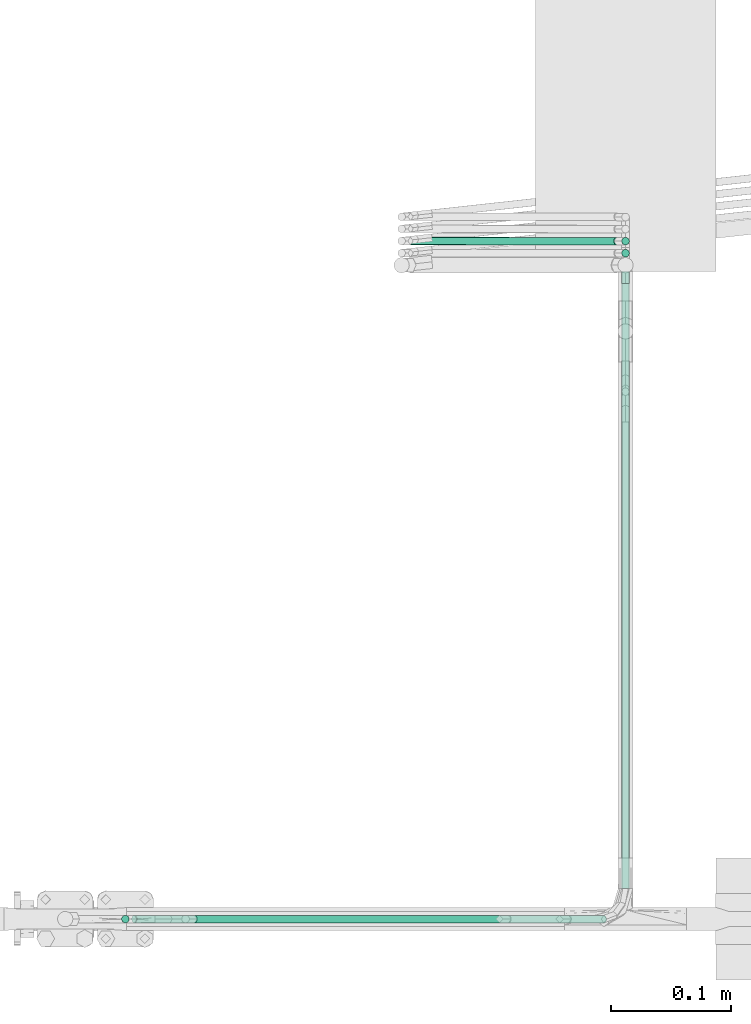
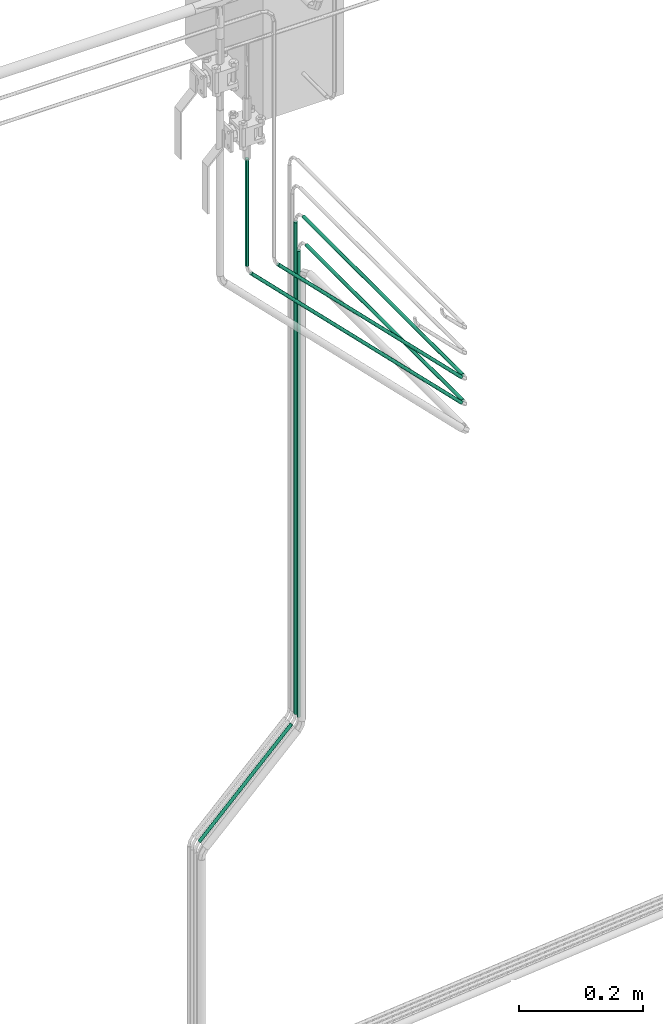
# One storey, part 11 of 45: 8 flow segments.
"""IFC2X3 building model written with IfcOpenShell, lengths in millimetres."""

from ifc_helpers import new_model, entity, si_unit, converted_unit, derived_unit, direction, frame, origin, origin_2d_with_axis, place, context, subcontext, project, spatial, circle, extrude, type_object, element, save


model = new_model("IFC2X3")

# Units and contexts
model_context = context("Model", 3, precision=0.01, world=origin(), true_north=direction((6.12303176911189e-17, 1.0)))
body_context = subcontext(model_context, "Body", "Model", "MODEL_VIEW")
ifc_project = project(units=[si_unit("LENGTHUNIT", "METRE", prefix="MILLI"), si_unit("AREAUNIT", "SQUARE_METRE"), si_unit("VOLUMEUNIT", "CUBIC_METRE"), converted_unit("PLANEANGLEUNIT", "DEGREE", entity("IfcRatioMeasure", 0.0174532925199433), si_unit("PLANEANGLEUNIT", "RADIAN"), dimensions=[0, 0, 0, 0, 0, 0, 0]), si_unit("MASSUNIT", "GRAM", prefix="KILO"), derived_unit("MASSDENSITYUNIT", [(si_unit("MASSUNIT", "GRAM", prefix="KILO"), 1), (si_unit("LENGTHUNIT", "METRE"), -3)]), derived_unit("MOMENTOFINERTIAUNIT", [(si_unit("LENGTHUNIT", "METRE"), 4)]), si_unit("TIMEUNIT", "SECOND"), si_unit("FREQUENCYUNIT", "HERTZ"), si_unit("THERMODYNAMICTEMPERATUREUNIT", "DEGREE_CELSIUS"), derived_unit("THERMALTRANSMITTANCEUNIT", [(si_unit("MASSUNIT", "GRAM", prefix="KILO"), 1), (si_unit("THERMODYNAMICTEMPERATUREUNIT", "KELVIN"), -1), (si_unit("TIMEUNIT", "SECOND"), -3)]), derived_unit("VOLUMETRICFLOWRATEUNIT", [(si_unit("LENGTHUNIT", "METRE"), 3), (si_unit("TIMEUNIT", "SECOND"), -1)]), derived_unit("MASSFLOWRATEUNIT", [(si_unit("MASSUNIT", "GRAM", prefix="KILO"), 1), (si_unit("TIMEUNIT", "SECOND"), -1)]), derived_unit("ROTATIONALFREQUENCYUNIT", [(si_unit("TIMEUNIT", "SECOND"), -1)]), si_unit("ELECTRICCURRENTUNIT", "AMPERE"), si_unit("ELECTRICVOLTAGEUNIT", "VOLT"), si_unit("POWERUNIT", "WATT"), si_unit("FORCEUNIT", "NEWTON", prefix="KILO"), si_unit("ILLUMINANCEUNIT", "LUX"), si_unit("LUMINOUSFLUXUNIT", "LUMEN"), si_unit("LUMINOUSINTENSITYUNIT", "CANDELA"), derived_unit("USERDEFINED", [(si_unit("MASSUNIT", "GRAM", prefix="KILO"), -1), (si_unit("LENGTHUNIT", "METRE"), -2), (si_unit("TIMEUNIT", "SECOND"), 3), (si_unit("LUMINOUSFLUXUNIT", "LUMEN"), 1)]), derived_unit("LINEARVELOCITYUNIT", [(si_unit("LENGTHUNIT", "METRE"), 1), (si_unit("TIMEUNIT", "SECOND"), -1)]), si_unit("PRESSUREUNIT", "PASCAL"), derived_unit("USERDEFINED", [(si_unit("LENGTHUNIT", "METRE"), -2), (si_unit("MASSUNIT", "GRAM", prefix="KILO"), 1), (si_unit("TIMEUNIT", "SECOND"), -2)]), derived_unit("LINEARFORCEUNIT", [(si_unit("MASSUNIT", "GRAM", prefix="KILO"), 1), (si_unit("LENGTHUNIT", "METRE"), 1), (si_unit("TIMEUNIT", "SECOND"), -2), (si_unit("LENGTHUNIT", "METRE"), -1)]), derived_unit("PLANARFORCEUNIT", [(si_unit("MASSUNIT", "GRAM", prefix="KILO"), 1), (si_unit("LENGTHUNIT", "METRE"), 1), (si_unit("TIMEUNIT", "SECOND"), -2), (si_unit("LENGTHUNIT", "METRE"), -2)])], contexts=[model_context])

# Site, building, storey
site_placement = place(None, frame((-24836.06, 8968.75, 0.0)))
site = spatial("IfcSite", under=ifc_project, at=site_placement, CompositionType="ELEMENT")
building_placement = place(site_placement, origin())
building = spatial("IfcBuilding", under=site, at=building_placement, CompositionType="ELEMENT")
storey_placement = place(building_placement, frame((0.0, 0.0, -4200.0)))
storey = spatial("IfcBuildingStorey", under=building, at=storey_placement, CompositionType="ELEMENT", Elevation=-4200.0)

# Flow segments
pipe_segment_type = type_object("IfcPipeSegmentType", PredefinedType="NOTDEFINED")
flow_segment_1_placement = place(storey_placement, frame((69646.14, -8388.67, 296.57)))
element("IfcFlowSegment", 1, at=flow_segment_1_placement, inside=storey, type_object=pipe_segment_type, context=body_context, shape_type="SweptSolid", body=[
    extrude(circle(Radius=3.175, at=origin_2d_with_axis()), frame((4.77, 4.77, 0.0), z_axis=(0.0, 0.0, 1.0), x_axis=(-1.0, 0.0, 0.0)), (0.0, 0.0, 1.0), 914.078975515724),
])
flow_segment_2_placement = place(storey_placement, frame((69646.14, -8911.84, 1231.28)))
element("IfcFlowSegment", 2, at=flow_segment_2_placement, inside=storey, type_object=pipe_segment_type, context=body_context, shape_type="SweptSolid", body=[
    extrude(circle(Radius=3.175, at=origin_2d_with_axis()), frame((4.77, 0.0, 4.77), z_axis=(0.0, 1.0, 0.0), x_axis=(-1.0, 0.0, 0.0)), (0.0, 0.0, 1.0), 502.548419713841),
])
flow_segment_3_placement = place(storey_placement, frame((69238.91, -8942.01, 1250.17)))
element("IfcFlowSegment", 3, at=flow_segment_3_placement, inside=storey, type_object=pipe_segment_type, context=body_context, shape_type="SweptSolid", body=[
    extrude(circle(Radius=3.175, at=origin_2d_with_axis()), frame((394.03, 4.77, 3.84), z_axis=(-0.707106781186548, 0.0, 0.707106781186548), x_axis=(0.0, 1.0, 0.0)), (0.0, 0.0, 1.0), 551.817503152151),
])
flow_segment_4_placement = place(storey_placement, frame((69230.54, -8942.01, 1662.17)))
element("IfcFlowSegment", 4, at=flow_segment_4_placement, inside=storey, type_object=pipe_segment_type, context=body_context, shape_type="SweptSolid", body=[
    extrude(circle(Radius=3.175, at=origin_2d_with_axis()), frame((4.77, 4.77, 0.0)), (0.0, 0.0, 1.0), 210.047077626279),
])
flow_segment_5_placement = place(storey_placement, frame((69468.46, -8378.67, 103.6)))
element("IfcFlowSegment", 5, at=flow_segment_5_placement, inside=storey, type_object=pipe_segment_type, context=body_context, shape_type="SweptSolid", body=[
    extrude(circle(Radius=3.175, at=origin_2d_with_axis()), frame((3.84, 4.89, 3.84), z_axis=(0.707106693002193, -0.000499422688143305, 0.707106693002182), x_axis=(0.000706290250846567, 0.99999975057701, 0.0)), (0.0, 0.0, 1.0), 242.072796011465),
])
flow_segment_6_placement = place(storey_placement, frame((69646.14, -8378.67, 296.57)))
element("IfcFlowSegment", 6, at=flow_segment_6_placement, inside=storey, type_object=pipe_segment_type, context=body_context, shape_type="SweptSolid", body=[
    extrude(circle(Radius=3.175, at=origin_2d_with_axis()), frame((4.77, 4.77, 0.0), z_axis=(0.0, 0.0, 1.0), x_axis=(-1.0, 0.0, 0.0)), (0.0, 0.0, 1.0), 964.078975515724),
])
flow_segment_7_placement = place(storey_placement, frame((69646.14, -8911.84, 1281.28)))
element("IfcFlowSegment", 7, at=flow_segment_7_placement, inside=storey, type_object=pipe_segment_type, context=body_context, shape_type="SweptSolid", body=[
    extrude(circle(Radius=3.175, at=origin_2d_with_axis()), frame((4.77, 0.0, 4.77), z_axis=(0.0, 1.0, 0.0), x_axis=(-1.0, 0.0, 0.0)), (0.0, 0.0, 1.0), 512.548419713843),
])
flow_segment_8_placement = place(storey_placement, frame((69288.91, -8942.01, 1300.17)))
element("IfcFlowSegment", 8, at=flow_segment_8_placement, inside=storey, type_object=pipe_segment_type, context=body_context, shape_type="SweptSolid", body=[
    extrude(circle(Radius=3.175, at=origin_2d_with_axis()), frame((344.03, 4.77, 3.84), z_axis=(-0.707106781186542, 0.0, 0.707106781186553), x_axis=(0.0, -1.0, 0.0)), (0.0, 0.0, 1.0), 481.10682503349),
])

save(model, "model.ifc")
